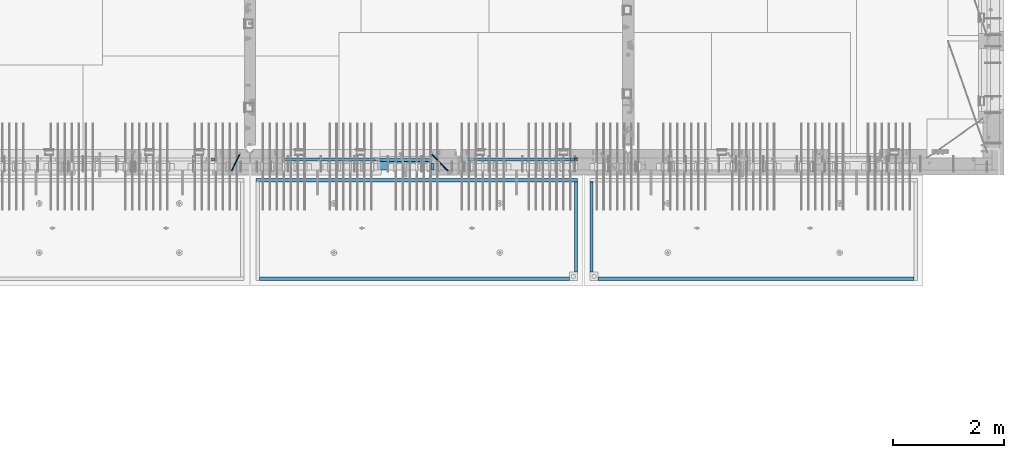
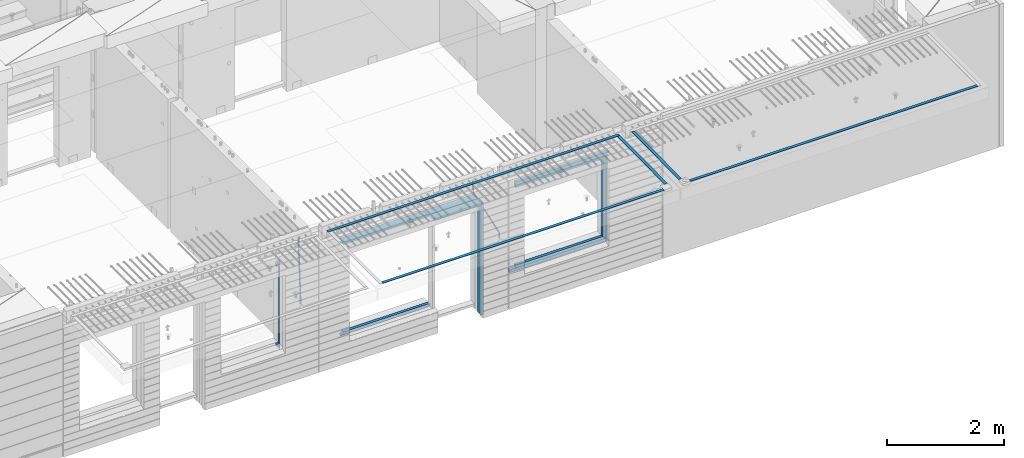
# One storey, part 97 of 350: 22 beams, 5 elements without a shape of their own.
"""IFC2X3 building model written with IfcOpenShell, lengths in millimetres."""

from ifc_helpers import new_model, si_unit, frame, origin_with_axes, place, context, subcontext, project, spatial, faceted_brep, material, type_object, element, aggregate, save


model = new_model("IFC2X3")

# Units and contexts
model_context = context("Model", 3, precision=1e-05, world=origin_with_axes())
body_context = subcontext(model_context, "Body", "Model", "MODEL_VIEW")
ifc_project = project(units=[si_unit("LENGTHUNIT", "METRE", prefix="MILLI"), si_unit("AREAUNIT", "SQUARE_METRE"), si_unit("VOLUMEUNIT", "CUBIC_METRE"), si_unit("MASSUNIT", "GRAM", prefix="KILO"), si_unit("TIMEUNIT", "SECOND"), si_unit("PLANEANGLEUNIT", "RADIAN"), si_unit("SOLIDANGLEUNIT", "STERADIAN"), si_unit("THERMODYNAMICTEMPERATUREUNIT", "DEGREE_CELSIUS"), si_unit("LUMINOUSINTENSITYUNIT", "LUMEN")], contexts=[model_context])

# Site, building, storey
site_placement = place(None, origin_with_axes())
site = spatial("IfcSite", under=ifc_project, at=site_placement, CompositionType="ELEMENT")
building_placement = place(site_placement, origin_with_axes())
building = spatial("IfcBuilding", under=site, at=building_placement, CompositionType="ELEMENT")
storey_placement = place(building_placement, origin_with_axes())
storey = spatial("IfcBuildingStorey", under=building, at=storey_placement, Name="2", CompositionType="ELEMENT", Elevation=0.0)

# Assembly, beams
assembly_1_placement = place(storey_placement, origin_with_axes())
assembly_1 = element("IfcElementAssembly", 1, at=assembly_1_placement, inside=storey, AssemblyPlace="NOTDEFINED", PredefinedType="REINFORCEMENT_UNIT")
ifc_material_1 = material(Name="CONCRETE/C35/45")
beam_type_1 = type_object("IfcBeamType", PredefinedType="NOTDEFINED")
beam_1_placement = place(assembly_1_placement, frame((24034.9998642727, 7815.0, 87140.0), z_axis=(0.0, 0.0, -1.0), x_axis=(1.0, 0.0, 0.0)))
beam_1 = element("IfcBeam", 2, at=beam_1_placement, type_object=beam_type_1, material=ifc_material_1, Name="SK", context=body_context, shape_type="Brep", body=[
    faceted_brep([(70.0000000000164, -35.0, 35.0), (70.0000000000164, 35.0, 35.0), (0.0, -35.0, -35.0), (1039.99961853026, -35.0, -35.0), (980.889062997325, -35.0, 35.0), (980.889062997325, 35.0, 35.0)], [[[0, 1, 2]], [[0, 2, 3, 4]], [[1, 0, 4, 5]], [[2, 1, 5, 3]], [[4, 3, 5]]]),
])
ifc_material_2 = material(Name="TIMBER")
beam_type_2 = type_object("IfcBeamType", Name="50X150", PredefinedType="NOTDEFINED")
beam_2_placement = place(assembly_1_placement, frame((24104.9998642727, 7705.0, 87080.0), z_axis=(0.0, 0.0, -1.0), x_axis=(1.0, 0.0, 0.0)))
beam_2 = element("IfcBeam", 3, at=beam_2_placement, type_object=beam_type_2, material=ifc_material_2, ObjectType="50X150", context=body_context, shape_type="Brep", body=[
    faceted_brep([(50.0000000000036, -75.0, 25.0), (50.0000000000036, 75.0, 25.0), (0.0, 75.0, -25.0), (0.0, -75.0, -25.0), (1009.99961853027, -75.0, -25.0), (959.999618530259, -75.0, 25.0), (959.999618530259, 75.0, 25.0), (1009.99961853027, 75.0, -25.0)], [[[0, 1, 2, 3]], [[0, 3, 4, 5]], [[1, 0, 5, 6]], [[2, 1, 6, 7]], [[3, 2, 7, 4]], [[6, 5, 4, 7]]]),
])

# Assembly, beam
assembly_2_placement = place(storey_placement, origin_with_axes())
assembly_2 = element("IfcElementAssembly", 4, at=assembly_2_placement, inside=storey, AssemblyPlace="NOTDEFINED", PredefinedType="REINFORCEMENT_UNIT")
ifc_material_3 = material()
beam_type_3 = type_object("IfcBeamType", Name="D20", PredefinedType="NOTDEFINED")
beam_3_placement = place(assembly_2_placement, frame((21625.0073331492, 7924.99999997881, 87407.5), z_axis=(-0.000415599999849952, -0.999999913638316, 0.0), x_axis=(-6.05680000062309e-05, -4.00000390151988e-09, -0.999999998165759)))
beam_3 = element("IfcBeam", 5, at=beam_3_placement, type_object=beam_type_3, material=ifc_material_3, Name="JM20", ObjectType="D20", context=body_context, shape_type="Brep", body=[
    faceted_brep([(-0.00060564729210455, -9.99999998165731, 0.0), (-0.000428079845733009, -7.07106779890455, -7.07106781186667), (119.575515501536, -7.07830994756296, -7.07106481604933), (119.575337932896, -10.0072421307195, -3.43332612828817e-06), (0.0, 0.0, -10.0), (119.575943836026, -0.00724214867295814, -9.99999700418266), (0.00042843479604926, 7.07106779888636, -7.07106781186303), (119.57637202373, 7.06382565022977, -7.07106481604933), (0.00060564729210455, 9.99999998166459, 3.63797880709171e-12), (119.576549238118, 9.99275783300072, 2.99581552098971e-06), (0.000428079845733009, 7.07106779890819, 7.07106781186667), (119.576371669405, 7.06382565024978, 7.07107080768037), (0.0, 0.0, 10.0), (119.57594333493, -0.00724214864203532, 10.0000029958155), (-0.000428434810601175, -7.07106779888272, 7.07106781186667), (119.575515147211, -7.07830994754295, 7.07107080768037), (123.006973508192, -7.07825951346604, -6.96785036235087), (122.582196132164, -10.0072047447829, 0.090452766209637), (123.182421564867, -0.00718632049392909, -9.89150999405319), (123.005765870272, 7.06387605862983, -6.9678969281922), (122.5804889344, 9.99279518261392, 0.090375952400791), (122.155712218591, 7.06384995171538, 7.14866812117907), (121.980264161975, -0.00722324126036256, 10.0723277528814), (122.156919856599, -7.07828562038412, 7.14871468701676), (235.904703171851, -7.06860422895625, -0.169508357435916), (235.479926262604, -9.99754169577864, 6.88878701985595), (236.080151695453, 0.002465748351824, -3.09317573838871), (235.903496467319, 7.07353134315781, -0.16957042179456), (235.478219724217, 10.0024582304504, 6.88869924890878), (235.053442814489, 7.07352076285679, 13.9469946275131), (234.877994290917, 0.00245078554871725, 16.8706620084649), (235.05464951905, -7.06861480925727, 13.9470566918726), (247.69730842374, 6.49890140729985, 1.5904257279044), (247.708271375333, -0.564091162203113, -1.35790592567901), (246.351191555892, -7.5775885142175, 1.3894260566567), (244.421027918448, -10.4331790195793, 8.22307186000126), (243.04844414418, -7.45809648886643, 15.1399744532118), (243.037481192529, -0.395103919359826, 18.0883061067871), (244.394561011999, 6.61839343264, 15.3409741244495), (246.324724649443, 9.47398393802723, 8.50732832109588), (256.620302657771, 7.90789673379186, 11.9850227549905), (258.892076862918, 4.79603600307382, 5.371853429986), (253.26121545503, 5.26966351612282, 18.3359992487194), (250.782522980895, -1.57322241172369, 20.7044670154446), (250.636209669712, -8.61229127897968, 17.7030097594688), (252.907983874131, -11.724152010418, 11.0898404357176), (256.267071077629, -9.08591879203959, 4.7388639407518), (258.745763551793, -2.24303286420036, 2.37039617402661), (1008.47908473376, -166.485147783689, 337.205828025195), (1005.11999753102, -169.123381001344, 343.556804518913), (1010.95777720789, -159.642261855857, 334.837360258474), (1011.10409051905, -152.60319298859, 337.838817514449), (1008.83231631388, -149.491332257865, 344.451986839456), (1005.47322911114, -152.129565475519, 350.802963333173), (1002.99453663701, -158.972451403351, 353.171431099895), (1002.84822332587, -166.011520270618, 350.169973843918), (1010.17087503639, -166.839152352099, 337.953575170377), (1008.40147312843, -169.810024819315, 345.007169854448), (1011.47638800017, -159.75078038171, 335.066578819891), (1011.55326023143, -152.697181073247, 338.037344110582), (1010.35646101969, -149.810257238067, 345.125637025791), (1008.58705911171, -152.781129705283, 352.179231709861), (1007.28154614793, -159.869501675676, 355.066228060347), (1007.20467391667, -166.923100984135, 352.095462769656), (1012.05411677422, -166.839038287919, 337.953575122971), (1012.05429688386, -169.809803575103, 345.007169762499), (1012.05368737834, -159.750745415844, 335.066578805359), (1012.05326023052, -152.697150789249, 338.037344097996), (1012.05308554815, -149.81015447692, 345.125636983083), (1012.05326565779, -152.780919764096, 352.179231622609), (1012.05369505366, -159.869212636178, 355.066227940223), (1012.05412220149, -166.92280726277, 352.095462647586), (1117.510115663, -166.832651029355, 337.953572468433), (1117.51029577265, -169.803416316539, 345.00716710796), (1117.50968626713, -159.744358157277, 335.06657615082), (1117.50925911931, -152.690763530685, 338.037341443456), (1117.50908443694, -149.803767218353, 345.125634328543), (1117.50926454658, -152.774532505533, 352.17922896807), (1117.50969394245, -159.862825377615, 355.066225285684), (1117.51012109026, -166.916420004207, 352.095459993046)], [[[0, 1, 2, 3]], [[1, 4, 5, 2]], [[4, 6, 7, 5]], [[6, 8, 9, 7]], [[8, 10, 11, 9]], [[10, 12, 13, 11]], [[12, 14, 15, 13]], [[14, 0, 3, 15]], [[14, 12, 10, 8, 6, 4, 1, 0]], [[3, 2, 16, 17]], [[2, 5, 18, 16]], [[5, 7, 19, 18]], [[7, 9, 20, 19]], [[9, 11, 21, 20]], [[11, 13, 22, 21]], [[13, 15, 23, 22]], [[15, 3, 17, 23]], [[17, 16, 24, 25]], [[16, 18, 26, 24]], [[18, 19, 27, 26]], [[19, 20, 28, 27]], [[20, 21, 29, 28]], [[21, 22, 30, 29]], [[22, 23, 31, 30]], [[23, 17, 25, 31]], [[26, 27, 32, 33]], [[24, 26, 33, 34]], [[25, 24, 34, 35]], [[31, 25, 35, 36]], [[30, 31, 36, 37]], [[29, 30, 37, 38]], [[28, 29, 38, 39]], [[27, 28, 39, 32]], [[39, 40, 41, 32]], [[38, 42, 40, 39]], [[37, 43, 42, 38]], [[36, 44, 43, 37]], [[35, 45, 44, 36]], [[34, 46, 45, 35]], [[33, 47, 46, 34]], [[32, 41, 47, 33]], [[45, 46, 48, 49]], [[46, 47, 50, 48]], [[47, 41, 51, 50]], [[41, 40, 52, 51]], [[40, 42, 53, 52]], [[42, 43, 54, 53]], [[43, 44, 55, 54]], [[44, 45, 49, 55]], [[49, 48, 56, 57]], [[48, 50, 58, 56]], [[50, 51, 59, 58]], [[51, 52, 60, 59]], [[52, 53, 61, 60]], [[53, 54, 62, 61]], [[54, 55, 63, 62]], [[55, 49, 57, 63]], [[57, 56, 64, 65]], [[56, 58, 66, 64]], [[58, 59, 67, 66]], [[59, 60, 68, 67]], [[60, 61, 69, 68]], [[61, 62, 70, 69]], [[62, 63, 71, 70]], [[63, 57, 65, 71]], [[65, 64, 72, 73]], [[64, 66, 74, 72]], [[66, 67, 75, 74]], [[67, 68, 76, 75]], [[68, 69, 77, 76]], [[69, 70, 78, 77]], [[70, 71, 79, 78]], [[71, 65, 73, 79]], [[74, 75, 76, 77, 78, 79, 73, 72]]]),
])

# Beam
beam_4_placement = place(assembly_1_placement, frame((25075.0293329014, 7924.99999993642, 87407.5), z_axis=(-0.000415599999849952, -0.999999913638316, 0.0), x_axis=(-0.000242263999929879, 0.0, -0.999999970654077)))
beam_4 = element("IfcBeam", 6, at=beam_4_placement, type_object=beam_type_3, material=ifc_material_3, Name="JM20", ObjectType="D20", context=body_context, shape_type="Brep", body=[
    faceted_brep([(-0.00060564729210455, -9.99999998165731, 0.0), (-0.000428079845733009, -7.07106779890455, -7.07106781186667), (119.575515501536, -7.07830994756296, -7.07106481604933), (119.575337932896, -10.0072421307195, -3.43332612828817e-06), (0.0, 0.0, -10.0), (119.575943836026, -0.00724214867295814, -9.99999700418266), (0.00042843479604926, 7.07106779888636, -7.07106781186303), (119.57637202373, 7.06382565022977, -7.07106481604933), (0.00060564729210455, 9.99999998166459, 3.63797880709171e-12), (119.576549238118, 9.99275783300072, 2.99581552098971e-06), (0.000428079845733009, 7.07106779890819, 7.07106781186667), (119.576371669405, 7.06382565024978, 7.07107080768037), (0.0, 0.0, 10.0), (119.57594333493, -0.00724214864203532, 10.0000029958155), (-0.000428434810601175, -7.07106779888272, 7.07106781186667), (119.575515147211, -7.07830994754295, 7.07107080768037), (123.008274907785, -7.07795567963694, -6.96780325792497), (122.584029738471, -10.0069316327917, 0.0905081323508057), (123.182440752484, -0.00686994861462153, -9.89150922917906), (123.004503280346, 7.06417944043824, -6.96794247666548), (122.578695849254, 9.99306765562687, 0.0903112464729929), (122.15445067735, 7.0640917031651, 7.14862263591931), (121.980284832651, -0.0069940278553986, 10.072328607177), (122.158222304832, -7.07804341691372, 7.14876185467801), (233.088395941915, -7.04853267872386, -0.33914435535371), (232.664150764584, -9.97750862893736, 6.71916703474017), (233.262561786629, 0.0225530520438042, -3.26285032724809), (233.08462431423, 7.09360244138225, -0.339283575355694), (232.658816882788, 10.0224906572403, 6.71897014756632), (232.234571710651, 7.09351470543697, 13.777281537301), (232.060405865923, 0.0224289746693103, 16.7009875091953), (232.238343338337, -7.04862041468004, 13.7774207573038), (248.070459246126, -5.60737147376494, 1.85103242021069), (247.013897852143, -8.59717146491312, 8.81690765643543), (244.865343898215, -5.8339984379636, 15.6233189364948), (242.883391151001, 1.06351832306973, 18.2831628436061), (242.22904064988, 8.05490704629119, 15.2383388907911), (243.285602043848, 11.0447070374539, 8.27246365456904), (245.434155997835, 8.28153401051895, 1.46605237452331), (247.416108745019, 1.38401724946743, -1.19379153259433), (260.512945877912, 5.37327174938764, 3.16696371259513), (261.933955342625, -1.38459511741894, 6.46705632785779), (256.86166640259, 11.762316953962, 5.27098446848322), (253.118986913221, 14.0399244660766, 11.5466117722399), (251.477318295016, 10.8719026949148, 18.3176682617204), (252.898327759729, 4.11403582813364, 21.6177608769931), (256.54960723508, -2.27500937642981, 19.5137401211105), (260.292286730517, -4.55261688891915, 13.2381128181169), (1011.6899267952, 318.016952836686, 337.688913324002), (1010.04825817693, 314.848931065488, 344.459969813425), (1010.26891733034, 324.774819703332, 334.388820708672), (1006.61763785462, 331.163864907652, 336.492841464405), (1002.87495836492, 333.441472419578, 342.76846876801), (1001.23328974665, 330.273450648383, 349.539525257433), (1002.6542992115, 323.515583781733, 352.839617872763), (1006.30557868723, 317.12653857741, 350.73559711703), (1012.11607330808, 318.198494379605, 337.877173297548), (1011.23010097447, 315.352404773395, 344.982075913254), (1011.34812648257, 325.234570724882, 334.865586047124), (1009.37611333313, 332.338995712049, 337.711461129013), (1007.35521241752, 335.350093536494, 344.747723517063), (1006.46924008391, 332.504003930284, 351.85262613277), (1007.23718690944, 325.467927585003, 354.864213383194), (1009.20920005886, 318.363502597836, 352.018338301305), (1012.61607329341, 318.198615511596, 337.877173247205), (1012.61676345688, 315.352740711776, 344.982075773638), (1012.61436835937, 325.234877489685, 334.865585919631), (1012.61264738202, 332.339779807688, 337.71146080314), (1012.61191848651, 335.351367047057, 344.747722987787), (1012.61260864999, 332.505492247237, 351.852625514221), (1012.61431358402, 325.469230269144, 354.864212841793), (1012.61603456138, 318.364327951142, 352.018337958285), (1117.42297412557, 318.224006449098, 337.87716269464), (1117.42366428903, 315.378131649279, 344.982065221072), (1117.42126919153, 325.260268427191, 334.865575367066), (1117.41954821418, 332.365170745194, 337.711450250575), (1117.41881931867, 335.376757984559, 344.747712435222), (1117.41950948215, 332.530883184736, 351.852614961655), (1117.42121441617, 325.494621206646, 354.864202289227), (1117.42293539354, 318.389718888644, 352.018327405719)], [[[0, 1, 2, 3]], [[1, 4, 5, 2]], [[4, 6, 7, 5]], [[6, 8, 9, 7]], [[8, 10, 11, 9]], [[10, 12, 13, 11]], [[12, 14, 15, 13]], [[14, 0, 3, 15]], [[14, 12, 10, 8, 6, 4, 1, 0]], [[3, 2, 16, 17]], [[2, 5, 18, 16]], [[5, 7, 19, 18]], [[7, 9, 20, 19]], [[9, 11, 21, 20]], [[11, 13, 22, 21]], [[13, 15, 23, 22]], [[15, 3, 17, 23]], [[17, 16, 24, 25]], [[16, 18, 26, 24]], [[18, 19, 27, 26]], [[19, 20, 28, 27]], [[20, 21, 29, 28]], [[21, 22, 30, 29]], [[22, 23, 31, 30]], [[23, 17, 25, 31]], [[25, 24, 32, 33]], [[31, 25, 33, 34]], [[30, 31, 34, 35]], [[29, 30, 35, 36]], [[28, 29, 36, 37]], [[27, 28, 37, 38]], [[26, 27, 38, 39]], [[24, 26, 39, 32]], [[39, 40, 41, 32]], [[38, 42, 40, 39]], [[37, 43, 42, 38]], [[36, 44, 43, 37]], [[35, 45, 44, 36]], [[34, 46, 45, 35]], [[33, 47, 46, 34]], [[32, 41, 47, 33]], [[47, 41, 48, 49]], [[41, 40, 50, 48]], [[40, 42, 51, 50]], [[42, 43, 52, 51]], [[43, 44, 53, 52]], [[44, 45, 54, 53]], [[45, 46, 55, 54]], [[46, 47, 49, 55]], [[49, 48, 56, 57]], [[48, 50, 58, 56]], [[50, 51, 59, 58]], [[51, 52, 60, 59]], [[52, 53, 61, 60]], [[53, 54, 62, 61]], [[54, 55, 63, 62]], [[55, 49, 57, 63]], [[57, 56, 64, 65]], [[56, 58, 66, 64]], [[58, 59, 67, 66]], [[59, 60, 68, 67]], [[60, 61, 69, 68]], [[61, 62, 70, 69]], [[62, 63, 71, 70]], [[63, 57, 65, 71]], [[65, 64, 72, 73]], [[64, 66, 74, 72]], [[66, 67, 75, 74]], [[67, 68, 76, 75]], [[68, 69, 77, 76]], [[69, 70, 78, 77]], [[70, 71, 79, 78]], [[71, 65, 73, 79]], [[74, 75, 76, 77, 78, 79, 73, 72]]]),
])

# Assembly, beams
assembly_3_placement = place(storey_placement, origin_with_axes())
assembly_3 = element("IfcElementAssembly", 7, at=assembly_3_placement, inside=storey, AssemblyPlace="NOTDEFINED", PredefinedType="REINFORCEMENT_UNIT")
ifc_material_4 = material(Name="CONCRETE/Concrete_Undefined")
beam_type_4 = type_object("IfcBeamType", PredefinedType="NOTDEFINED")
beam_5_placement = place(assembly_3_placement, frame((27949.9413896323, 7420.0548526853, 87725.6636564041), z_axis=(3.20999999465459e-07, -0.00901957599816896, 0.999959322797038), x_axis=(3.55380000057318e-05, -0.999959322165559, -0.00901957600149657)))
beam_5 = element("IfcBeam", 8, at=beam_5_placement, type_object=beam_type_4, material=ifc_material_4, context=body_context, shape_type="Brep", body=[
    faceted_brep([(2.5465851649642e-11, 29.9999999999982, -4.99999999998545), (-2.91038304567337e-11, 29.9999999999982, 5.0), (1625.35189228369, 30.0000000000073, 5.0), (1625.35189228371, 30.0000000000073, -5.0), (-2.5465851649642e-11, -30.0000000000018, 5.0), (1625.35189228368, -29.9999999999927, 5.00000000001455), (2.72848410531878e-11, -30.0000000000018, -4.99999999998545), (1625.35189228371, -29.9999999999927, -4.99999999998545)], [[[0, 1, 2, 3]], [[1, 4, 5, 2]], [[4, 6, 7, 5]], [[6, 0, 3, 7]], [[5, 7, 3, 2]], [[6, 4, 1, 0]]]),
])
beam_6_placement = place(assembly_3_placement, frame((33750.1798578673, 5674.89208457699, 87711.2777998596), z_axis=(-0.00010875600001081, -1.00000033862182e-09, 0.999999994086066), x_axis=(-0.999999994070015, -5.66600000038745e-06, -0.000108756000006807)))
beam_6 = element("IfcBeam", 9, at=beam_6_placement, type_object=beam_type_4, material=ifc_material_4, context=body_context, shape_type="Brep", body=[
    faceted_brep([(2.5465851649642e-11, 29.9999999999982, -4.99999999998545), (-2.91038304567337e-11, 29.9999999999982, 5.0), (5682.56261276337, 30.0, 5.0), (5682.56261276337, 30.0, -5.0), (-2.5465851649642e-11, -30.0000000000018, 5.0), (5682.56261276337, -30.0, 5.0), (2.72848410531878e-11, -30.0000000000018, -4.99999999998545), (5682.56261276337, -30.0, -5.0)], [[[0, 1, 2, 3]], [[1, 4, 5, 2]], [[4, 6, 7, 5]], [[6, 0, 3, 7]], [[5, 7, 3, 2]], [[6, 4, 1, 0]]]),
])
aggregate(assembly_3, [beam_5, beam_6])

assembly_4_placement = place(storey_placement, origin_with_axes())
assembly_4 = element("IfcElementAssembly", 10, at=assembly_4_placement, inside=storey, AssemblyPlace="NOTDEFINED", PredefinedType="REINFORCEMENT_UNIT")
beam_7_placement = place(assembly_4_placement, frame((27670.0013901304, 7419.94686420498, 87725.2791047129), z_axis=(-7.99999906695021e-09, -0.0106298469955396, 0.99994350158039), x_axis=(-7.67999998664137e-07, -0.999943501580095, -0.0106298469955353)))
beam_7 = element("IfcBeam", 11, at=beam_7_placement, type_object=beam_type_4, material=ifc_material_4, context=body_context, shape_type="Brep", body=[
    faceted_brep([(2.5465851649642e-11, 29.9999999999982, -4.99999999998545), (-2.91038304567337e-11, 29.9999999999982, 5.0), (1625.17584384035, 29.9999999999964, 5.0), (1625.17584384035, 30.0000000000036, -4.99999999998545), (-2.5465851649642e-11, -30.0000000000018, 5.0), (1625.17584384035, -30.0, 5.0), (2.72848410531878e-11, -30.0000000000018, -4.99999999998545), (1625.17584384035, -29.9999999999964, -4.99999999998545)], [[[0, 1, 2, 3]], [[1, 4, 5, 2]], [[4, 6, 7, 5]], [[6, 0, 3, 7]], [[5, 7, 3, 2]], [[6, 4, 1, 0]]]),
])
beam_8_placement = place(assembly_4_placement, frame((27700.0033616247, 7449.93184428144, 87725.2788442816), z_axis=(6.6541999986247e-05, -1.00000033832184e-09, 0.999999997786081), x_axis=(-0.999999997707994, 1.24969999963762e-05, 6.65419999798477e-05)))
beam_8 = element("IfcBeam", 12, at=beam_8_placement, type_object=beam_type_4, material=ifc_material_4, context=body_context, shape_type="Brep", body=[
    faceted_brep([(2.5465851649642e-11, 29.9999999999982, -4.99999999998545), (-2.91038304567337e-11, 29.9999999999982, 5.0), (5780.0600107005, 30.0, 5.00000000001455), (5780.0600107005, 30.0000000000009, -5.0), (-2.5465851649642e-11, -30.0000000000018, 5.0), (5780.0600107005, -30.0000000000009, 5.00000000001455), (2.72848410531878e-11, -30.0000000000018, -4.99999999998545), (5780.0600107005, -30.0, -4.99999999998545)], [[[0, 1, 2, 3]], [[1, 4, 5, 2]], [[4, 6, 7, 5]], [[6, 0, 3, 7]], [[5, 7, 3, 2]], [[6, 4, 1, 0]]]),
])
beam_9_placement = place(assembly_4_placement, frame((21979.9397016438, 5674.8679591, 87709.8457712343), z_axis=(0.000327872000083623, 1.99999976807677e-09, 0.999999946249974), x_axis=(0.999999946233322, 5.77100000136594e-06, -0.000327872000077393)))
beam_9 = element("IfcBeam", 13, at=beam_9_placement, type_object=beam_type_4, material=ifc_material_4, context=body_context, shape_type="Brep", body=[
    faceted_brep([(2.5465851649642e-11, 29.9999999999982, -4.99999999998545), (-2.91038304567337e-11, 29.9999999999982, 5.0), (5570.052902922, 30.0000000000009, 5.00000000001455), (5570.05290292199, 30.0000000000009, -4.99999999998545), (-2.5465851649642e-11, -30.0000000000018, 5.0), (5570.052902922, -30.0, 5.00000000001455), (2.72848410531878e-11, -30.0000000000018, -4.99999999998545), (5570.05290292199, -30.0, -4.99999999998545)], [[[0, 1, 2, 3]], [[1, 4, 5, 2]], [[4, 6, 7, 5]], [[6, 0, 3, 7]], [[5, 7, 3, 2]], [[6, 4, 1, 0]]]),
])
aggregate(assembly_4, [beam_7, beam_8, beam_9])

# Beam
beam_type_5 = type_object("IfcBeamType", PredefinedType="NOTDEFINED")
beam_10_placement = place(assembly_2_placement, frame((21144.9998642727, 7820.0, 87175.0), z_axis=(-1.0, 3.00000001838171e-08, 0.0), x_axis=(0.0, 0.0, -1.0)))
beam_10 = element("IfcBeam", 14, at=beam_10_placement, type_object=beam_type_5, material=ifc_material_1, Name="SK", context=body_context, shape_type="Brep", body=[
    faceted_brep([(1740.94594594595, -30.0, 30.0), (1739.32432432432, 30.0, 30.0), (1739.32432432432, 30.0, -24.3243243243269), (1740.94594594595, -30.0, -25.9459459459504), (115.67567567568, 30.0, -24.3243243243269), (114.054054054053, -30.0, -25.9459459459504), (115.67567567568, 30.0, 30.0), (114.054054054053, -30.0, 30.0), (72.2635272671032, 30.0, 30.0), (72.2635272671032, -30.0, 30.0), (0.0, 30.0, -30.0), (0.0, -30.0, -30.0), (1855.0, -30.0, -30.0), (1782.73647273288, -30.0, 30.0), (1782.73647273287, 30.0, 30.0), (1855.0, 30.0, -30.0)], [[[0, 1, 2, 3]], [[3, 2, 4, 5]], [[5, 4, 6, 7]], [[7, 6, 8, 9]], [[10, 11, 9, 8]], [[0, 3, 5, 7, 9, 11, 12, 13]], [[1, 0, 13, 14]], [[10, 8, 6, 4, 2, 1, 14, 15]], [[15, 12, 11, 10]], [[15, 14, 13, 12]]]),
])

beam_11_placement = place(assembly_1_placement, frame((22384.9998642751, 7820.0, 87145.0), z_axis=(0.0, 0.0, -1.0), x_axis=(1.0, 0.0, 0.0)))
beam_11 = element("IfcBeam", 15, at=beam_11_placement, type_object=beam_type_5, material=ifc_material_1, Name="SK", context=body_context, shape_type="Brep", body=[
    faceted_brep([(1820.00000000026, -30.0, 30.0), (1820.00000000026, -30.0, -30.0), (1820.00000000026, 30.0, 30.0), (49.817662327685, -30.0, 30.0), (0.0, -30.0, -30.0), (49.817662327685, 30.0, 30.0)], [[[0, 1, 2]], [[1, 0, 3, 4]], [[2, 1, 4, 5]], [[0, 2, 5, 3]], [[4, 3, 5]]]),
])

beam_12_placement = place(assembly_1_placement, frame((22384.9998642751, 7820.0, 87085.0), z_axis=(0.0, 0.0, -1.0), x_axis=(1.0, 0.0, 0.0)))
beam_12 = element("IfcBeam", 16, at=beam_12_placement, type_object=beam_type_5, material=ifc_material_1, Name="SK", context=body_context, shape_type="Brep", body=[
    faceted_brep([(1820.00000000026, -30.0, -30.0), (1820.00000000026, 30.0, -30.0), (1820.00000000026, 30.0, 25.6756756756804), (1820.00000000026, -30.0, 24.0540540540678), (59.8219112435072, 30.0, 25.6756756756804), (58.0795254791192, -30.0, 24.0540540540533), (0.0, -30.0, -30.0), (0.0, 30.0, -30.0)], [[[0, 1, 2, 3]], [[3, 2, 4, 5]], [[0, 3, 5, 6]], [[6, 7, 1, 0]], [[2, 1, 7, 4]], [[4, 7, 6, 5]]]),
])

beam_13_placement = place(assembly_1_placement, frame((24144.9998642753, 7820.0, 85150.0), z_axis=(0.0, 0.0, 1.0), x_axis=(-1.0, 3.00000001838171e-08, 0.0)))
beam_13 = element("IfcBeam", 17, at=beam_13_placement, type_object=beam_type_5, material=ifc_material_1, Name="SK", context=body_context, shape_type="Brep", body=[
    faceted_brep([(0.0, -30.0, 30.0), (-5.28234522789717e-09, 30.0, 30.0), (0.0, -30.0, -30.0), (1710.18233767259, -30.0, 30.0), (1710.18233767259, 30.0, 30.0), (1760.00000000026, -30.0, -30.0)], [[[0, 1, 2]], [[1, 0, 3, 4]], [[2, 1, 4, 5]], [[0, 2, 5, 3]], [[4, 3, 5]]]),
])

beam_14_placement = place(assembly_1_placement, frame((24144.9998642753, 7820.0, 85210.0), z_axis=(0.0, 0.0, 1.0), x_axis=(-1.0, 3.00000001838171e-08, 0.0)))
beam_14 = element("IfcBeam", 18, at=beam_14_placement, type_object=beam_type_5, material=ifc_material_1, Name="SK", context=body_context, shape_type="Brep", body=[
    faceted_brep([(0.0, 30.0, -30.0), (0.0, -30.0, -30.0), (0.0, -30.0, 24.0540540540678), (0.0, 30.0, 25.6756756756804), (1700.17808875675, 30.0, 25.6756756756804), (1760.00000000026, 30.0, -30.0), (1760.00000000026, -30.0, -30.0), (1701.92047452114, -30.0, 24.0540540540533)], [[[0, 1, 2, 3]], [[0, 3, 4, 5]], [[1, 0, 5, 6]], [[2, 1, 6, 7]], [[3, 2, 7, 4]], [[6, 5, 4, 7]]]),
])

# Assembly, beams
assembly_5_placement = place(storey_placement, origin_with_axes())
assembly_5 = element("IfcElementAssembly", 19, at=assembly_5_placement, inside=storey, AssemblyPlace="NOTDEFINED", PredefinedType="REINFORCEMENT_UNIT")
beam_15_placement = place(assembly_5_placement, frame((25845.0006272121, 7820.0, 87145.0), z_axis=(0.0, 0.0, -1.0), x_axis=(1.0, 0.0, 0.0)))
beam_15 = element("IfcBeam", 20, at=beam_15_placement, type_object=beam_type_5, material=ifc_material_1, Name="SK", context=body_context, shape_type="Brep", body=[
    faceted_brep([(0.0, -30.0, -30.0), (0.0, -30.0, 30.0), (-5.28234522789717e-09, 30.0, 30.0), (0.0, 30.0, -30.0), (1849.99885559082, -30.0, -30.0), (1789.99885559081, -30.0, 30.0), (1789.99885559081, 30.0, 30.0), (1849.99885559082, 30.0, -30.0)], [[[0, 1, 2, 3]], [[1, 0, 4, 5]], [[2, 1, 5, 6]], [[3, 2, 6, 7]], [[0, 3, 7, 4]], [[6, 5, 4, 7]]]),
])
beam_16_placement = place(assembly_5_placement, frame((25845.0006272121, 7820.0, 87085.0), z_axis=(0.0, 0.0, -1.0), x_axis=(1.0, 0.0, 0.0)))
beam_16 = element("IfcBeam", 21, at=beam_16_placement, type_object=beam_type_5, material=ifc_material_1, Name="SK", context=body_context, shape_type="Brep", body=[
    faceted_brep([(1725.94480153677, -30.0, 24.0540540540533), (1724.32317991515, 30.0, 25.6756756756804), (5.67453126650071, 30.0, 25.6756756756804), (4.05290964487722, -30.0, 24.0540540540533), (5.67453126650071, 30.0, 30.0), (4.05290964487722, -30.0, 30.0), (-5.28234522789717e-09, 30.0, 30.0), (0.0, -30.0, 30.0), (0.0, -30.0, -30.0), (0.0, 30.0, -30.0), (1789.99885559082, -30.0, -30.0), (1725.94480153677, -30.0, 24.9034748914273), (1724.32317991515, 30.0, 26.293436281092), (1789.99885559082, 30.0, -30.0)], [[[0, 1, 2, 3]], [[4, 5, 3, 2]], [[6, 7, 5, 4]], [[8, 7, 6, 9]], [[0, 3, 5, 7, 8, 10, 11]], [[1, 0, 11, 12]], [[9, 6, 4, 2, 1, 12, 13]], [[8, 9, 13, 10]], [[12, 11, 10, 13]]]),
])
beam_17_placement = place(assembly_5_placement, frame((27664.9994828029, 7820.0, 87175.0), z_axis=(-1.0, 3.00000001838171e-08, 0.0), x_axis=(0.0, 0.0, -1.0)))
beam_17 = element("IfcBeam", 22, at=beam_17_placement, type_object=beam_type_5, material=ifc_material_1, Name="SK", context=body_context, shape_type="Brep", body=[
    faceted_brep([(60.0000000000073, 30.0, 30.0), (0.0, -30.0, -30.0), (60.0000000000073, -30.0, 30.0), (1855.0, -30.0, -30.0), (1795.00000000001, -30.0, 30.0), (1795.00000000001, 30.0, 30.0)], [[[0, 1, 2]], [[3, 4, 2, 1]], [[4, 5, 0, 2]], [[5, 3, 1, 0]], [[4, 3, 5]]]),
])
beam_18_placement = place(assembly_5_placement, frame((27694.9994828029, 7820.0, 85350.0), z_axis=(0.0, 0.0, 1.0), x_axis=(-1.0, 3.00000001838171e-08, 0.0)))
beam_18 = element("IfcBeam", 23, at=beam_18_placement, type_object=beam_type_5, material=ifc_material_1, Name="SK", context=body_context, shape_type="Brep", body=[
    faceted_brep([(1969.99885559082, -30.0, 30.0), (1969.99885559082, -30.0, -30.0), (1969.99885559082, 30.0, -30.0), (1969.99885559082, 30.0, 30.0), (0.0, -30.0, -30.0), (0.0, 30.0, -30.0), (60.0000000000073, 30.0, 30.0), (60.0000000000073, -30.0, 30.0)], [[[0, 1, 2, 3]], [[2, 1, 4, 5]], [[3, 2, 5, 6]], [[0, 3, 6, 7]], [[1, 0, 7, 4]], [[6, 5, 4, 7]]]),
])
ifc_material_5 = material(Name="CONCRETE/C40/50")
beam_19_placement = place(assembly_5_placement, frame((27634.9994828029, 7820.0, 85410.0), z_axis=(0.0, 0.0, 1.0), x_axis=(-1.0, 3.00000001838171e-08, 0.0)))
beam_19 = element("IfcBeam", 24, at=beam_19_placement, type_object=beam_type_5, material=ifc_material_5, Name="SK", context=body_context, shape_type="Brep", body=[
    faceted_brep([(1785.94594594595, -30.0, 24.0540540540533), (1784.32432432433, 30.0, 25.6756756756804), (65.6756756756768, 30.0, 25.6756756756804), (64.0540540540533, -30.0, 24.0540540540533), (1784.32432432432, 30.0, 30.0), (1785.94594594595, -30.0, 30.0), (1789.99885559081, -30.0, 30.0), (1789.99885559081, 30.0, 30.0), (1789.99885559082, -30.0, -30.0), (1789.99885559082, 30.0, -30.0), (0.0, -30.0, -30.0), (0.0, 30.0, -30.0), (65.6756756756768, 30.0, 26.293436281092), (64.0540540540533, -30.0, 24.9034748914419)], [[[0, 1, 2, 3]], [[4, 1, 0, 5]], [[6, 7, 4, 5]], [[6, 8, 9, 7]], [[10, 11, 9, 8]], [[2, 1, 4, 7, 9, 11, 12]], [[3, 2, 12, 13]], [[8, 6, 5, 0, 3, 13, 10]], [[10, 13, 12, 11]]]),
])

# Beam
beam_type_6 = type_object("IfcBeamType", PredefinedType="NOTDEFINED")
beam_20_placement = place(assembly_2_placement, frame((21139.9998642727, 7820.0, 87115.0), z_axis=(-1.0, 3.00000001838171e-08, 0.0), x_axis=(0.0, 0.0, -1.0)))
beam_20 = element("IfcBeam", 25, at=beam_20_placement, type_object=beam_type_6, material=ifc_material_5, Name="SK", context=body_context, shape_type="Brep", body=[
    faceted_brep([(1680.94594594595, -30.0, -30.9459459459504), (1679.32432432432, 30.0, -29.3243243243269), (55.6756756756804, 30.0, -29.3243243243269), (54.0540540540533, -30.0, -30.9459459459504), (55.6756756756804, 30.0, 24.8219112435145), (54.0540540540533, -30.0, 23.0795254791374), (0.0, 30.0, -35.0), (0.0, -30.0, -35.0), (1735.0, -30.0, -35.0), (1680.94594594595, -30.0, 23.0795254791337), (1679.32432432432, 30.0, 24.8219112435145), (1735.0, 30.0, -35.0)], [[[0, 1, 2, 3]], [[3, 2, 4, 5]], [[4, 6, 7, 5]], [[0, 3, 5, 7, 8, 9]], [[1, 0, 9, 10]], [[6, 4, 2, 1, 10, 11]], [[11, 8, 7, 6]], [[10, 9, 8, 11]]]),
])

aggregate(assembly_2, [beam_3, beam_10, beam_20])

beam_21_placement = place(assembly_5_placement, frame((27599.9994828029, 7820.0, 87115.0), z_axis=(-1.0, 3.00000001838171e-08, 0.0), x_axis=(0.0, 0.0, -1.0)))
beam_21 = element("IfcBeam", 26, at=beam_21_placement, type_object=beam_type_6, material=ifc_material_1, Name="SK", context=body_context, shape_type="Brep", body=[
    faceted_brep([(0.0, -30.0, -35.0), (54.9034748914273, -30.0, 29.0540540540533), (56.2934362811066, 30.0, 30.6756756756768), (0.0, 30.0, -35.0), (1735.0, -30.0, -35.0), (1680.09652510857, -30.0, 29.0540540540533), (1678.70656371891, 30.0, 30.6756756756768), (1735.0, 30.0, -35.0)], [[[0, 1, 2, 3]], [[1, 0, 4, 5]], [[2, 1, 5, 6]], [[3, 2, 6, 7]], [[7, 4, 0, 3]], [[4, 7, 6, 5]]]),
])

aggregate(assembly_5, [beam_15, beam_16, beam_17, beam_21, beam_18, beam_19])

beam_type_7 = type_object("IfcBeamType", Name="50X120", PredefinedType="NOTDEFINED")
beam_22_placement = place(assembly_1_placement, frame((25089.9994828029, 7690.0, 87105.0), z_axis=(-1.0, 3.00000001838171e-08, 0.0), x_axis=(0.0, 0.0, -1.0)))
beam_22 = element("IfcBeam", 27, at=beam_22_placement, type_object=beam_type_7, material=ifc_material_2, ObjectType="50X120", context=body_context, shape_type="Brep", body=[
    faceted_brep([(2345.0, -60.0, 25.0), (2345.0, -60.0, -25.0), (2345.0, 60.0, -25.0), (2345.0, 60.0, 25.0), (0.0, -60.0, -25.0), (0.0, 60.0, -25.0), (50.0000000000036, 60.0, 25.0), (50.0000000000036, -60.0, 25.0)], [[[0, 1, 2, 3]], [[4, 5, 2, 1]], [[3, 2, 5, 6]], [[0, 3, 6, 7]], [[1, 0, 7, 4]], [[5, 4, 7, 6]]]),
])

aggregate(assembly_1, [beam_4, beam_11, beam_12, beam_13, beam_14, beam_1, beam_2, beam_22])

save(model, "model.ifc")
